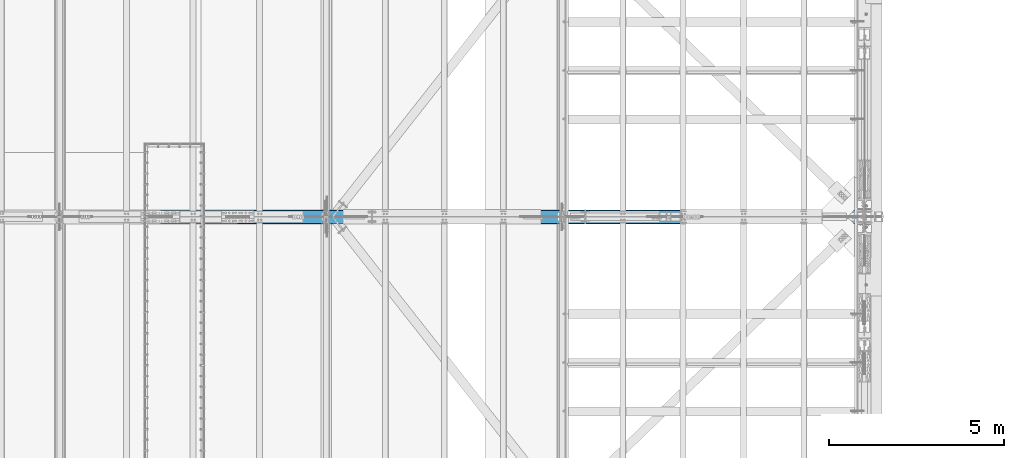
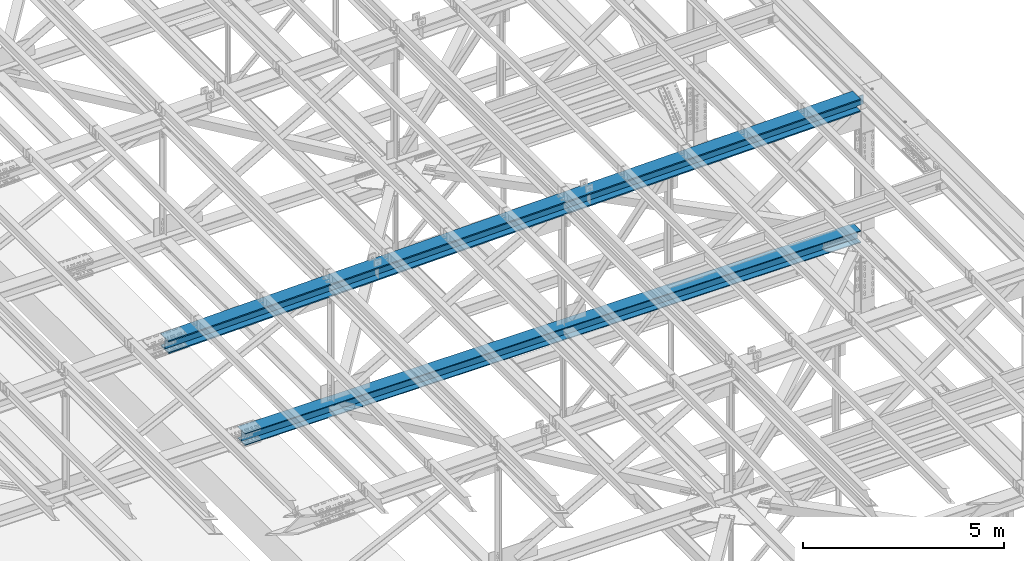
# One storey, part 1855 of 3843: 2 beams, 2 elements without a shape of their own.
"""IFC2X3 building model written with IfcOpenShell, lengths in millimetres."""

from ifc_helpers import new_model, si_unit, frame, origin_with_axes, place, context, subcontext, project, spatial, faceted_brep, material, type_object, element, aggregate, save


model = new_model("IFC2X3")

# Units and contexts
model_context = context("Model", 3, precision=1e-05, world=origin_with_axes())
body_context = subcontext(model_context, "Body", "Model", "MODEL_VIEW")
ifc_project = project(units=[si_unit("LENGTHUNIT", "METRE", prefix="MILLI"), si_unit("AREAUNIT", "SQUARE_METRE"), si_unit("VOLUMEUNIT", "CUBIC_METRE"), si_unit("MASSUNIT", "GRAM", prefix="KILO"), si_unit("TIMEUNIT", "SECOND"), si_unit("PLANEANGLEUNIT", "RADIAN"), si_unit("SOLIDANGLEUNIT", "STERADIAN"), si_unit("THERMODYNAMICTEMPERATUREUNIT", "DEGREE_CELSIUS"), si_unit("LUMINOUSINTENSITYUNIT", "LUMEN")], contexts=[model_context])

# Site, building, storey
site_placement = place(None, origin_with_axes())
site = spatial("IfcSite", under=ifc_project, at=site_placement, CompositionType="ELEMENT")
building_placement = place(site_placement, origin_with_axes())
building = spatial("IfcBuilding", under=site, at=building_placement, Name="Undefined", CompositionType="ELEMENT")
storey_placement = place(building_placement, origin_with_axes())
storey = spatial("IfcBuildingStorey", under=building, at=storey_placement, Name="Undefined", CompositionType="ELEMENT", Elevation=0.0)

# Assembly, beam
assembly_1_placement = place(storey_placement, origin_with_axes())
assembly_1 = element("IfcElementAssembly", 1, at=assembly_1_placement, inside=storey, Name="BEAM", AssemblyPlace="NOTDEFINED", PredefinedType="RIGID_FRAME")
ifc_material = material(Name="STEEL/A992")
beam_type_1 = type_object("IfcBeamType", Name="W14X193", PredefinedType="NOTDEFINED")
beam_1_placement = place(assembly_1_placement, frame((65510.881105248, 50558.7, 45930.6766199244), z_axis=(-0.0198294219936798, 0.0, 0.99980337768153), x_axis=(0.99980337768153, 0.0, 0.0198294219936836)))
beam_1 = element("IfcBeam", 2, at=beam_1_placement, type_object=beam_type_1, material=ifc_material, Name="BEAM", ObjectType="W14X193", context=body_context, shape_type="Brep", body=[
    faceted_brep([(19920.463875985, -11.1125000000029, -159.949243870928), (19920.463875985, -200.025000000001, -159.949243870928), (19920.3939389119, -200.025000000001, -196.461676866449), (19920.3939389119, 200.025000000001, -196.461676866449), (19920.463875985, 200.025000000001, -159.949243870928), (19920.463875985, 11.1125000000029, -159.949243870928), (19920.4791608036, 11.1125000000029, -151.969414451909), (19920.4791608036, -11.1125000000029, -151.969414451909), (19921.4551980863, 11.1125000000029, -147.111195551159), (19921.4551980863, -11.1125000000029, -147.111195551159), (19924.2160988388, 11.1125000000029, -142.996299841754), (19924.2160988388, -11.1125000000029, -142.996299841754), (19928.3415409493, 11.1125000000029, -140.251182893808), (19928.3415409493, -11.1125000000029, -140.251182893808), (19933.2034632535, 11.1125000000029, -139.293763878122), (19933.2034632535, -11.1125000000029, -139.293763878122), (20111.323099487, -11.1125000000029, -139.634939882999), (20111.323099487, 11.1125000000029, -139.634939882999), (16116.5535599763, 200.025000000001, 203.035235085015), (16116.5535599763, -200.025000000001, 203.035235085015), (18131.1690834689, -200.025000000001, 200.329035881477), (18131.1690834689, 200.025000000001, 200.329035881477), (14101.9371462332, 200.025000000001, 204.968234799315), (14101.9371462332, -200.025000000001, 204.968234799315), (12087.3201389895, 200.025000000001, 206.128034740294), (12087.3201389895, -200.025000000001, 206.128034740294), (10072.7028349956, 200.025000000001, 206.514634737527), (10072.7028349956, -200.025000000001, 206.514634737527), (8058.08553100166, 200.025000000001, 206.128034733265), (8058.08553100166, -200.025000000001, 206.128034733265), (6043.468523758, 200.025000000001, 204.968234785258), (6043.468523758, -200.025000000001, 204.968234785258), (4028.85211001484, 200.025000000001, 203.03523506393), (4028.85211001484, -200.025000000001, 203.03523506393), (2014.23658652228, 200.025000000001, 200.329035853363), (2014.23658652228, -200.025000000001, 200.329035853363), (5.97224307589931, 200.024999999994, 196.860604494032), (5.97224307589931, -200.024999999994, 196.860604494032), (18131.1130302353, 11.1125000000029, 163.81657890747), (18131.1130302353, 200.025000000001, 163.81657890747), (19927.4280965837, 200.025000000001, 160.714200718874), (19927.4280965837, 11.1125000000029, 160.714200718874), (16116.5115200439, 11.1125000000029, 166.522759287182), (16116.5115200439, 200.025000000001, 166.522759287182), (14101.9091196081, 11.1125000000029, 168.455745555875), (14101.9091196081, 200.025000000001, 168.455745555875), (12087.306125676, 11.1125000000029, 169.615537429498), (12087.306125676, 200.025000000001, 169.615537429498), (10072.7028349956, 11.1125000000029, 170.00213473761), (10072.7028349956, 200.025000000001, 170.00213473761), (8058.09954431529, 11.1125000000029, 169.615537422469), (8058.09954431529, 200.025000000001, 169.615537422469), (6043.49655038313, 11.1125000000029, 168.455745541818), (6043.49655038313, 200.025000000001, 168.455745541818), (4028.89414994734, 11.1125000000029, 166.522759266089), (4028.89414994734, 200.025000000001, 166.522759266089), (2014.29263975599, 11.1125000000029, 163.816578879349), (2014.29263975599, 200.025000000001, 163.816578879349), (6.04230920456757, 11.1125000000029, 160.348171721198), (6.04230920456757, 200.024999999994, 160.348171721198), (16116.1422997682, 200.025000000001, -154.152028154735), (16116.1422997682, 11.1125000000029, -154.152028154735), (18130.6207366188, 11.1125000000029, -156.858043212087), (18130.6207366188, 200.025000000001, -156.858043212087), (14101.6629727276, 200.025000000001, -152.219159973443), (14101.6629727276, 11.1125000000029, -152.219159973443), (12087.1830522269, 200.025000000001, -151.059438952274), (12087.1830522269, 11.1125000000029, -151.059438952274), (10072.7028349962, 200.025000000001, -150.672865261658), (10072.7028349962, 11.1125000000029, -150.672865261658), (8058.22261776545, 200.025000000001, -151.059438959302), (8058.22261776545, 11.1125000000029, -151.059438959302), (6043.74269726478, 200.025000000001, -152.219159987508), (6043.74269726478, 11.1125000000029, -152.219159987508), (4029.2633702242, 200.025000000001, -154.15202817582), (4029.2633702242, 11.1125000000029, -154.15202817582), (2014.78493337368, 200.025000000001, -156.858043240209), (2014.78493337368, 11.1125000000029, -156.858043240209), (6.657672595451, 200.024999999994, -160.326237848931), (6.657672595451, 11.1125000000029, -160.326237848931), (16116.1002598358, -200.025000000001, -190.664503952576), (16116.1002598358, 200.025000000001, -190.664503952576), (18130.5646833852, 200.025000000001, -193.370500186102), (18130.5646833852, -200.025000000001, -193.370500186102), (14101.6349461026, -200.025000000001, -188.731649216883), (14101.6349461026, 200.025000000001, -188.731649216883), (12087.1690389134, -200.025000000001, -187.571936263077), (12087.1690389134, 200.025000000001, -187.571936263077), (10072.7028349963, -200.025000000001, -187.185365261575), (10072.7028349963, 200.025000000001, -187.185365261575), (8058.23663107908, -200.025000000001, -187.571936270106), (8058.23663107908, 200.025000000001, -187.571936270106), (6043.77072388992, -200.025000000001, -188.731649230947), (6043.77072388992, 200.025000000001, -188.731649230947), (4029.30541015672, -200.025000000001, -190.664503973661), (4029.30541015672, 200.025000000001, -190.664503973661), (2014.84098660736, -200.025000000001, -193.370500214223), (2014.84098660736, 200.025000000001, -193.370500214223), (6.72773872410471, -200.024999999994, -196.838670621779), (6.72773872410471, 200.024999999994, -196.838670621779), (16116.1422997682, -11.1125000000029, -154.152028154735), (16116.1422997682, -200.025000000001, -154.152028154735), (18130.6207366188, -200.025000000001, -156.858043212087), (18130.6207366188, -11.1125000000029, -156.858043212087), (14101.6629727276, -11.1125000000029, -152.219159973443), (14101.6629727276, -200.025000000001, -152.219159973443), (12087.1830522269, -11.1125000000029, -151.059438952274), (12087.1830522269, -200.025000000001, -151.059438952274), (10072.7028349962, -11.1125000000029, -150.672865261658), (10072.7028349962, -200.025000000001, -150.672865261658), (8058.22261776545, -11.1125000000029, -151.059438959302), (8058.22261776545, -200.025000000001, -151.059438959302), (6043.74269726478, -11.1125000000029, -152.219159987508), (6043.74269726478, -200.025000000001, -152.219159987508), (4029.2633702242, -11.1125000000029, -154.15202817582), (4029.2633702242, -200.025000000001, -154.15202817582), (2014.78493337368, -11.1125000000029, -156.858043240209), (2014.78493337368, -200.025000000001, -156.858043240209), (6.657672595451, -11.1125000000029, -160.326237848931), (6.657672595451, -200.024999999994, -160.326237848931), (6.04230920456757, -11.1125000000029, 160.348171721198), (6.04230920456757, -200.024999999994, 160.348171721198), (2014.29263975599, -11.1125000000029, 163.816578879349), (2014.29263975599, -200.025000000001, 163.816578879349), (4028.89414994734, -11.1125000000029, 166.522759266089), (4028.89414994734, -200.025000000001, 166.522759266089), (6043.49655038313, -11.1125000000029, 168.455745541818), (6043.49655038313, -200.025000000001, 168.455745541818), (8058.09954431529, -11.1125000000029, 169.615537422469), (8058.09954431529, -200.025000000001, 169.615537422469), (10072.7028349956, -11.1125000000029, 170.00213473761), (10072.7028349956, -200.025000000001, 170.00213473761), (12087.306125676, -11.1125000000029, 169.615537429498), (12087.306125676, -200.025000000001, 169.615537429498), (14101.9091196081, -11.1125000000029, 168.455745555875), (14101.9091196081, -200.025000000001, 168.455745555875), (16116.5115200439, -11.1125000000029, 166.522759287182), (16116.5115200439, -200.025000000001, 166.522759287182), (18131.1130302353, -11.1125000000029, 163.81657890747), (18131.1130302353, -200.025000000001, 163.81657890747), (19927.4280965837, -11.1125000000029, 160.714200718874), (19927.4280965837, -200.025000000001, 160.714200718874), (19927.4980336568, -200.025000000001, 197.226633714396), (19927.4980336568, 200.025000000001, 197.226633714396), (19927.4129716879, -11.1125000000029, 152.817863060554), (19927.4129716879, 11.1125000000029, 152.817863060554), (19928.3703907036, -11.1125000000029, 147.955940756241), (19928.3703907036, 11.1125000000029, 147.955940756241), (19931.1155076515, -11.1125000000029, 143.830498645744), (19931.1155076515, 11.1125000000029, 143.830498645744), (19935.2304033609, -11.1125000000029, 141.069597893198), (19935.2304033609, 11.1125000000029, 141.069597893198), (19940.0886222616, -11.1125000000029, 140.093560610519), (19940.0886222616, 11.1125000000029, 140.093560610519), (20116.8643292184, -11.1125000000029, 139.754958810379), (20116.8643292184, 11.1125000000029, 139.754958810379)], [[[0, 1, 2, 3, 4, 5, 6, 7]], [[7, 6, 8, 9]], [[9, 8, 10, 11]], [[11, 10, 12, 13]], [[13, 12, 14, 15]], [[16, 15, 14, 17]], [[18, 19, 20, 21]], [[22, 23, 19, 18]], [[24, 25, 23, 22]], [[26, 27, 25, 24]], [[28, 29, 27, 26]], [[30, 31, 29, 28]], [[32, 33, 31, 30]], [[34, 35, 33, 32]], [[35, 34, 36, 37]], [[38, 39, 40, 41]], [[42, 43, 39, 38]], [[44, 45, 43, 42]], [[46, 47, 45, 44]], [[48, 49, 47, 46]], [[50, 51, 49, 48]], [[52, 53, 51, 50]], [[54, 55, 53, 52]], [[56, 57, 55, 54]], [[57, 56, 58, 59]], [[60, 61, 62, 63]], [[64, 65, 61, 60]], [[66, 67, 65, 64]], [[68, 69, 67, 66]], [[70, 71, 69, 68]], [[72, 73, 71, 70]], [[74, 75, 73, 72]], [[76, 77, 75, 74]], [[77, 76, 78, 79]], [[80, 81, 82, 83]], [[84, 85, 81, 80]], [[86, 87, 85, 84]], [[88, 89, 87, 86]], [[90, 91, 89, 88]], [[92, 93, 91, 90]], [[94, 95, 93, 92]], [[96, 97, 95, 94]], [[97, 96, 98, 99]], [[100, 101, 102, 103]], [[104, 105, 101, 100]], [[106, 107, 105, 104]], [[108, 109, 107, 106]], [[110, 111, 109, 108]], [[112, 113, 111, 110]], [[114, 115, 113, 112]], [[116, 117, 115, 114]], [[117, 116, 118, 119]], [[120, 121, 37, 36, 59, 58, 79, 78, 99, 98, 119, 118]], [[122, 123, 121, 120]], [[123, 122, 124, 125]], [[125, 124, 126, 127]], [[127, 126, 128, 129]], [[129, 128, 130, 131]], [[131, 130, 132, 133]], [[133, 132, 134, 135]], [[135, 134, 136, 137]], [[137, 136, 138, 139]], [[139, 138, 140, 141]], [[20, 19, 23, 25, 27, 29, 31, 33, 35, 37, 121, 123, 125, 127, 129, 131, 133, 135, 137, 139, 141, 142]], [[21, 20, 142, 143]], [[39, 43, 45, 47, 49, 51, 53, 55, 57, 59, 36, 34, 32, 30, 28, 26, 24, 22, 18, 21, 143, 40]], [[142, 141, 140, 144, 145, 41, 40, 143]], [[146, 147, 145, 144]], [[148, 149, 147, 146]], [[150, 151, 149, 148]], [[152, 153, 151, 150]], [[154, 155, 153, 152]], [[155, 154, 16, 17]], [[12, 10, 8, 6, 5, 62, 61, 65, 67, 69, 71, 73, 75, 77, 79, 58, 56, 54, 52, 50, 48, 46, 44, 42, 38, 41, 145, 147, 149, 151, 153, 155, 17, 14]], [[63, 62, 5, 4]], [[82, 81, 85, 87, 89, 91, 93, 95, 97, 99, 78, 76, 74, 72, 70, 68, 66, 64, 60, 63, 4, 3]], [[83, 82, 3, 2]], [[102, 101, 105, 107, 109, 111, 113, 115, 117, 119, 98, 96, 94, 92, 90, 88, 86, 84, 80, 83, 2, 1]], [[103, 102, 1, 0]], [[154, 152, 150, 148, 146, 144, 140, 138, 136, 134, 132, 130, 128, 126, 124, 122, 120, 118, 116, 114, 112, 110, 108, 106, 104, 100, 103, 0, 7, 9, 11, 13, 15, 16]]]),
])
aggregate(assembly_1, [beam_1])

assembly_2_placement = place(storey_placement, origin_with_axes())
assembly_2 = element("IfcElementAssembly", 3, at=assembly_2_placement, inside=storey, Name="BEAM", AssemblyPlace="NOTDEFINED", PredefinedType="RIGID_FRAME")
beam_type_2 = type_object("IfcBeamType", Name="W14X120", PredefinedType="NOTDEFINED")
beam_2_placement = place(assembly_2_placement, frame((67716.4, 50558.6999969886, 42344.365124027), z_axis=(0.0015305159996351, 0.0, 0.999998828759702), x_axis=(0.999998828759702, 0.0, -0.00153051599963216)))
beam_2 = element("IfcBeam", 4, at=beam_2_placement, type_object=beam_type_2, material=ifc_material, Name="BEAM", ObjectType="W14X120", context=body_context, shape_type="Brep", body=[
    faceted_brep([(3586.3184314305, -185.737500000003, 165.240493782316), (3586.3184314305, -7.14375000000291, 165.240493782316), (5379.61569266707, -7.14375000000291, 166.772752814395), (5379.61569266707, -185.737500000003, 166.772752814395), (1793.02179861856, -185.737500000003, 163.095331389857), (1793.02179861856, -7.14375000000291, 163.095331389857), (6.07599532067252, -185.737500000003, 160.347032091391), (6.07599532067252, -7.14375000000291, 160.347032091391), (14346.128509118, 185.737500000003, 189.052981285902), (14346.128509118, -185.737500000003, 189.052981285902), (16139.4332804319, -185.737500000003, 186.907809164899), (16139.4332804319, 185.737500000003, 186.907809164899), (12552.8231093767, 185.737500000003, 190.585247264986), (12552.8231093767, -185.737500000003, 190.585247264986), (10759.5172906837, 185.737500000003, 191.504606922426), (10759.5172906837, -185.737500000003, 191.504606922426), (8966.21126251483, 185.737500000003, 191.811060151085), (8966.21126251483, -185.737500000003, 191.811060151085), (7172.90523434595, 185.737500000003, 191.504606915594), (7172.90523434595, -185.737500000003, 191.504606915594), (5379.59941565292, 185.737500000003, 190.585247251336), (5379.59941565292, -185.737500000003, 190.585247251336), (3586.2940159116, 185.737500000003, 189.052981265413), (3586.2940159116, -185.737500000003, 189.052981265413), (1792.98924459773, 185.737500000003, 186.907809137585), (1792.98924459773, -185.737500000003, 186.907809137585), (6.03530269260227, 185.737500000003, 184.159497322114), (6.03530269260227, -185.737500000003, 184.159497322114), (14346.1040935989, 7.14375000000291, 165.240493802798), (14346.1040935989, 185.737500000003, 165.240493802798), (16139.4007264108, 185.737500000003, 163.095331417171), (16139.4007264108, 7.14375000000291, 163.095331417171), (12552.8068323623, 7.14375000000291, 166.772752828052), (12552.8068323623, 185.737500000003, 166.772752828052), (10759.509152176, 7.14375000000291, 167.692108313175), (10759.509152176, 185.737500000003, 167.692108313175), (8966.2112625147, 7.14375000000291, 167.998560151078), (8966.2112625147, 185.737500000003, 167.998560151078), (7172.91337285344, 7.14375000000291, 167.692108306357), (7172.91337285344, 185.737500000003, 167.692108306357), (5379.61569266707, 7.14375000000291, 166.772752814395), (5379.61569266707, 185.737500000003, 166.772752814395), (3586.3184314305, 7.14375000000291, 165.240493782316), (3586.3184314305, 185.737500000003, 165.240493782316), (1793.02179861856, 7.14375000000291, 163.095331389857), (1793.02179861856, 185.737500000003, 163.095331389857), (6.07599532067252, 7.14375000000291, 160.347032091391), (6.07599532067252, 185.737500000003, 160.347032091391), (14345.7752979409, 185.737500000003, -155.434337636281), (14345.7752979409, 7.14375000000291, -155.434337636281), (16138.9623322605, 7.14375000000291, -157.579368918909), (16138.9623322605, 185.737500000003, -157.579368918909), (12552.5876352351, 185.737500000003, -153.902172256028), (12552.5876352351, 7.14375000000291, -153.902172256028), (10759.3995536051, 185.737500000003, -152.982872957917), (10759.3995536051, 7.14375000000291, -152.982872957917), (8966.21126251298, 185.737500000003, -152.676439849027), (8966.21126251298, 7.14375000000291, -152.676439849027), (7173.02297142085, 185.737500000003, -152.982872964734), (7173.02297142085, 7.14375000000291, -152.982872964734), (5379.83488979084, 185.737500000003, -153.902172269693), (5379.83488979084, 7.14375000000291, -153.902172269693), (3586.64722708502, 185.737500000003, -155.434337656763), (3586.64722708502, 7.14375000000291, -155.434337656763), (1793.46019276544, 185.737500000003, -157.579368946223), (1793.46019276544, 7.14375000000291, -157.579368946223), (6.6239893786551, 185.737500000003, -160.327499682498), (6.6239893786551, 7.14375000000291, -160.327499682498), (14345.7508824217, -185.737500000003, -179.246825119379), (14345.7508824217, 185.737500000003, -179.246825119379), (16138.9297782394, 185.737500000003, -181.391846666636), (16138.9297782394, -185.737500000003, -181.391846666636), (12552.5713582207, -185.737500000003, -177.714666692969), (12552.5713582207, 185.737500000003, -177.714666692969), (10759.3914150974, -185.737500000003, -176.795371567154), (10759.3914150974, 185.737500000003, -176.795371567154), (8966.21126251285, -185.737500000003, -176.488939849027), (8966.21126251285, 185.737500000003, -176.488939849027), (7173.03110992834, -185.737500000003, -176.795371573986), (7173.03110992834, 185.737500000003, -176.795371573986), (5379.85116680499, -185.737500000003, -177.714666706626), (5379.85116680499, 185.737500000003, -177.714666706626), (3586.67164260392, -185.737500000003, -179.24682513986), (3586.67164260392, 185.737500000003, -179.24682513986), (1793.49274678624, -185.737500000003, -181.39184669395), (1793.49274678624, 185.737500000003, -181.39184669395), (6.66468200672534, -185.737500000003, -184.139964913236), (6.66468200672534, 185.737500000003, -184.139964913236), (6.6239893786551, -185.737500000003, -160.327499682498), (6.6239893786551, -7.14375000000291, -160.327499682498), (1793.46019276544, -185.737500000003, -157.579368946223), (1793.46019276544, -7.14375000000291, -157.579368946223), (3586.64722708502, -185.737500000003, -155.434337656763), (3586.64722708502, -7.14375000000291, -155.434337656763), (5379.83488979084, -185.737500000003, -153.902172269693), (5379.83488979084, -7.14375000000291, -153.902172269693), (7173.02297142085, -185.737500000003, -152.982872964734), (7173.02297142085, -7.14375000000291, -152.982872964734), (8966.21126251298, -185.737500000003, -152.676439849027), (8966.21126251298, -7.14375000000291, -152.676439849027), (10759.3995536051, -185.737500000003, -152.982872957917), (10759.3995536051, -7.14375000000291, -152.982872957917), (12552.5876352351, -185.737500000003, -153.902172256028), (12552.5876352351, -7.14375000000291, -153.902172256028), (14345.7752979409, -185.737500000003, -155.434337636281), (14345.7752979409, -7.14375000000291, -155.434337636281), (16138.9623322605, -185.737500000003, -157.579368918909), (16138.9623322605, -7.14375000000291, -157.579368918909), (17732.6406983194, -7.14375000000291, -160.030425417659), (17732.6406983194, -185.737500000003, -160.030425417659), (17732.6406983194, -147.637550459571, -160.030425417659), (16139.4007264108, -7.14375000000291, 163.095331417171), (14346.1040935989, -7.14375000000291, 165.240493802798), (12552.8068323623, -7.14375000000291, 166.772752828052), (10759.509152176, -7.14375000000291, 167.692108313175), (8966.2112625147, -7.14375000000291, 167.998560151078), (7172.91337285344, -7.14375000000291, 167.692108306357), (17732.1498978001, -7.14375000000291, 160.645704007678), (7172.91337285344, -185.737500000003, 167.692108306357), (8966.2112625147, -185.737500000003, 167.998560151078), (10759.509152176, -185.737500000003, 167.692108313175), (12552.8068323623, -185.737500000003, 166.772752828052), (14346.1040935989, -185.737500000003, 165.240493802798), (16139.4007264108, -185.737500000003, 163.095331417171), (17732.1498978001, -185.737500000003, 160.645704007678), (17732.113452217, -185.737500000003, 184.458287875888), (17732.113452217, 147.637449532849, 184.458287875888), (17732.113452217, 185.737500000003, 184.458287875888), (17732.113452217, -147.637550459571, 184.458287875888), (17732.1498978001, 185.737500000003, 160.645704007678), (17732.1498978001, 7.14375000000291, 160.645704007678), (17732.1498978001, 147.637449532849, 160.645704007678), (17732.5809315093, 7.14375000000291, -120.980366213218), (17732.6406983194, 7.14375000000291, -160.030425417659), (17732.2093528367, 7.14375000000291, 121.799349433204), (17732.6406983194, 185.737500000003, -160.030425417659), (17732.6406983194, 147.637449532849, -160.030425417659), (17732.6771439025, 185.737500000003, -183.843009285876), (17732.6771439025, -147.637550459571, -183.843009285876), (17732.6771439025, -185.737500000003, -183.843009285876), (17732.6771439025, 147.637449532849, -183.843009285876), (17732.1498978001, -147.637550459571, 160.645704007678)], [[[0, 1, 2, 3]], [[4, 5, 1, 0]], [[5, 4, 6, 7]], [[8, 9, 10, 11]], [[12, 13, 9, 8]], [[14, 15, 13, 12]], [[16, 17, 15, 14]], [[18, 19, 17, 16]], [[20, 21, 19, 18]], [[22, 23, 21, 20]], [[24, 25, 23, 22]], [[25, 24, 26, 27]], [[28, 29, 30, 31]], [[32, 33, 29, 28]], [[34, 35, 33, 32]], [[36, 37, 35, 34]], [[38, 39, 37, 36]], [[40, 41, 39, 38]], [[42, 43, 41, 40]], [[44, 45, 43, 42]], [[45, 44, 46, 47]], [[48, 49, 50, 51]], [[52, 53, 49, 48]], [[54, 55, 53, 52]], [[56, 57, 55, 54]], [[58, 59, 57, 56]], [[60, 61, 59, 58]], [[62, 63, 61, 60]], [[64, 65, 63, 62]], [[65, 64, 66, 67]], [[68, 69, 70, 71]], [[72, 73, 69, 68]], [[74, 75, 73, 72]], [[76, 77, 75, 74]], [[78, 79, 77, 76]], [[80, 81, 79, 78]], [[82, 83, 81, 80]], [[84, 85, 83, 82]], [[85, 84, 86, 87]], [[7, 6, 27, 26, 47, 46, 67, 66, 87, 86, 88, 89]], [[90, 91, 89, 88]], [[91, 90, 92, 93]], [[93, 92, 94, 95]], [[95, 94, 96, 97]], [[97, 96, 98, 99]], [[99, 98, 100, 101]], [[101, 100, 102, 103]], [[103, 102, 104, 105]], [[105, 104, 106, 107]], [[108, 107, 106, 109, 110]], [[111, 112, 113, 114, 115, 116, 2, 1, 5, 7, 89, 91, 93, 95, 97, 99, 101, 103, 105, 107, 108, 117]], [[3, 2, 116, 118]], [[10, 9, 13, 15, 17, 19, 21, 23, 25, 27, 6, 4, 0, 3, 118, 119, 120, 121, 122, 123, 124, 125]], [[126, 127, 11, 10, 125, 128]], [[30, 29, 33, 35, 37, 39, 41, 43, 45, 47, 26, 24, 22, 20, 18, 16, 14, 12, 8, 11, 127, 129]], [[130, 31, 30, 129, 131]], [[132, 133, 50, 49, 53, 55, 57, 59, 61, 63, 65, 67, 46, 44, 42, 40, 38, 36, 34, 32, 28, 31, 130, 134]], [[135, 51, 50, 133, 136]], [[70, 69, 73, 75, 77, 79, 81, 83, 85, 87, 66, 64, 62, 60, 58, 56, 54, 52, 48, 51, 135, 137]], [[138, 139, 71, 70, 137, 140]], [[106, 104, 102, 100, 98, 96, 94, 92, 90, 88, 86, 84, 82, 80, 78, 76, 74, 72, 68, 71, 139, 109]], [[138, 140, 137, 135, 136, 133, 132, 134, 130, 131, 129, 127, 126, 128, 125, 124, 141, 117, 108, 110, 109, 139]], [[124, 123, 111, 117, 141]], [[122, 112, 111, 123]], [[121, 113, 112, 122]], [[120, 114, 113, 121]], [[119, 115, 114, 120]], [[118, 116, 115, 119]]]),
])
aggregate(assembly_2, [beam_2])

save(model, "model.ifc")
